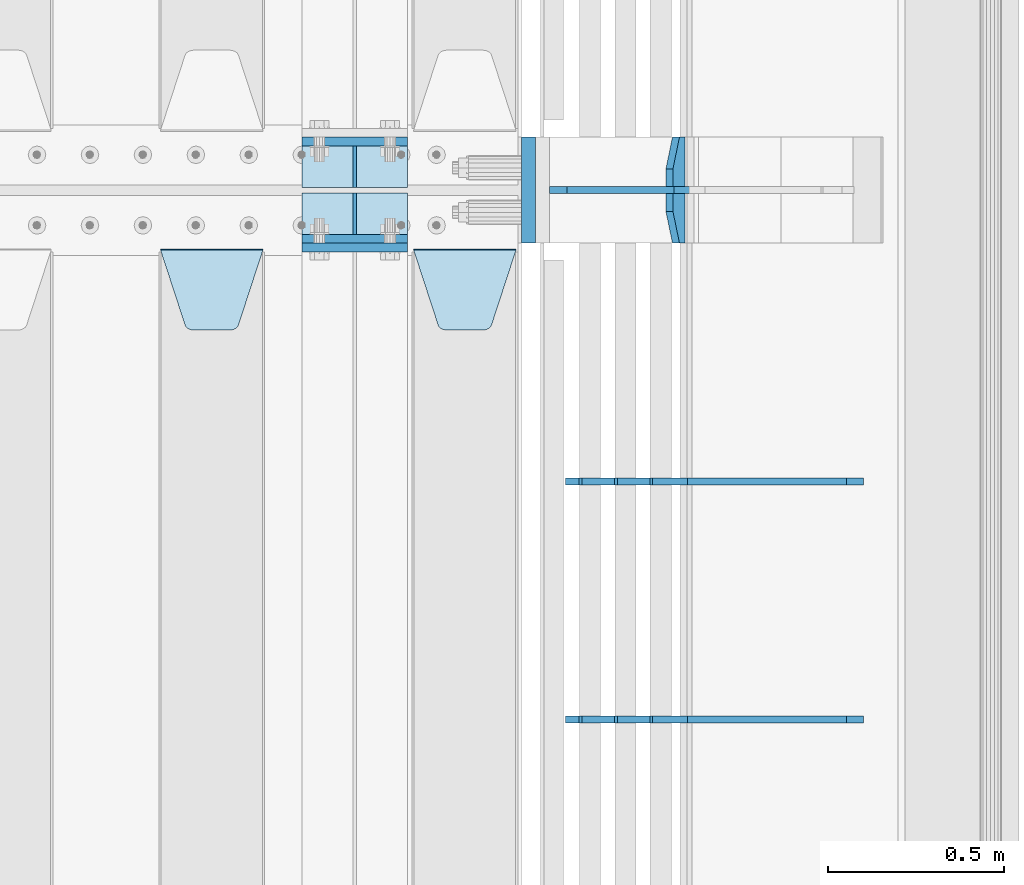
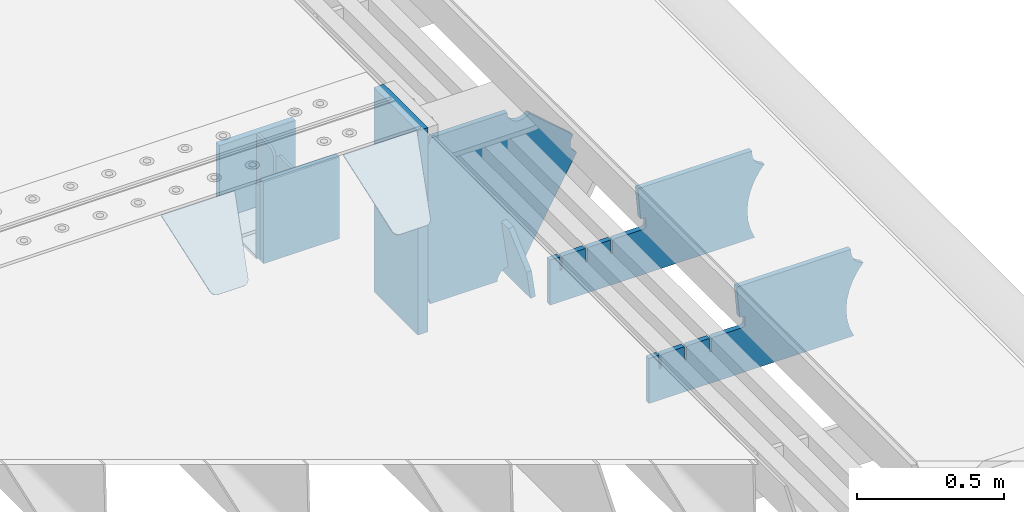
# One storey, part 170 of 193: 14 plates.
"""IFC2X3 building model written with IfcOpenShell, lengths in millimetres."""

from ifc_helpers import new_model, si_unit, frame, origin_with_axes, place, context, subcontext, project, spatial, faceted_brep, material, type_object, element, save


model = new_model("IFC2X3")

# Units and contexts
model_context = context("Model", 3, precision=1e-05, world=origin_with_axes())
body_context = subcontext(model_context, "Body", "Model", "MODEL_VIEW")
ifc_project = project(units=[si_unit("LENGTHUNIT", "METRE", prefix="MILLI"), si_unit("AREAUNIT", "SQUARE_METRE"), si_unit("VOLUMEUNIT", "CUBIC_METRE"), si_unit("MASSUNIT", "GRAM", prefix="KILO"), si_unit("TIMEUNIT", "SECOND"), si_unit("PLANEANGLEUNIT", "RADIAN"), si_unit("SOLIDANGLEUNIT", "STERADIAN"), si_unit("THERMODYNAMICTEMPERATUREUNIT", "DEGREE_CELSIUS"), si_unit("LUMINOUSINTENSITYUNIT", "LUMEN")], contexts=[model_context])

# Site, building, storey
site_placement = place(None, origin_with_axes())
site = spatial("IfcSite", under=ifc_project, at=site_placement, CompositionType="ELEMENT")
building_placement = place(site_placement, origin_with_axes())
building = spatial("IfcBuilding", under=site, at=building_placement, Name="Standard", CompositionType="ELEMENT")
storey_placement = place(building_placement, origin_with_axes())
storey = spatial("IfcBuildingStorey", under=building, at=storey_placement, Name="Undefined", CompositionType="ELEMENT", Elevation=0.0)

# Plates
ifc_material_1 = material(Name="STEEL/S355N")
plate_type_1 = type_object("IfcPlateType", PredefinedType="NOTDEFINED")
for number, where, z_axis, x_axis in (
    (1, (-29045.0, 27137.5, -339.999999999995), (0.0, 0.0, 1.0), (1.0, 0.0, 0.0)),
    (2, (-29045.0, 26862.5, -339.999999999995), (0.0, 0.0, 1.0), (1.0, 0.0, 0.0)),
):
    element("IfcPlate", number, at=place(storey_placement, frame(where, z_axis=z_axis, x_axis=x_axis)), inside=storey, type_object=plate_type_1, material=ifc_material_1, context=body_context, shape_type="Brep", body=[
        faceted_brep([(0.0, -12.5, 0.0), (0.0, -12.5, 310.0), (0.0, 12.5, 310.0), (0.0, 12.5, 0.0), (300.0, -12.5, 310.0), (300.0, 12.5, 310.0), (300.0, -12.5, 0.0), (300.0, 12.5, 0.0)], [[[0, 1, 2, 3]], [[1, 4, 5, 2]], [[4, 6, 7, 5]], [[6, 0, 3, 7]], [[5, 7, 3, 2]], [[6, 4, 1, 0]]]),
    ])
plate_1_placement = place(storey_placement, frame((-29045.0, 26837.5, -340.000000000044), z_axis=(0.0, 0.0, 1.0), x_axis=(1.0, 0.0, 0.0)))
element("IfcPlate", 3, at=plate_1_placement, inside=storey, type_object=plate_type_1, material=ifc_material_1, context=body_context, shape_type="Brep", body=[
    faceted_brep([(0.0, -12.5, 0.0), (9.27684595808387e-10, -12.5, 340.0), (9.27684595808387e-10, 12.5, 340.0), (0.0, 12.5, 0.0), (300.0, -12.5, 340.0), (300.0, 12.5, 340.0), (300.0, -12.5, 0.0), (300.0, 12.5, 0.0)], [[[0, 1, 2, 3]], [[1, 4, 5, 2]], [[4, 6, 7, 5]], [[6, 0, 3, 7]], [[5, 7, 3, 2]], [[6, 4, 1, 0]]]),
])
plate_type_2 = type_object("IfcPlateType", PredefinedType="NOTDEFINED")
for number, where, z_axis, x_axis in (
    (4, (-29045.0, 27008.0, -342.999999999995), (0.0, 1.0, 0.0), (1.0, 0.0, 0.0)),
    (5, (-29045.0, 26992.0, -342.999999999995), (0.0, -1.0, 0.0), (1.0, 0.0, 0.0)),
):
    element("IfcPlate", number, at=place(storey_placement, frame(where, z_axis=z_axis, x_axis=x_axis)), inside=storey, type_object=plate_type_2, material=ifc_material_1, context=body_context, shape_type="Brep", body=[
        faceted_brep([(0.0, -7.0, 0.0), (0.0, -7.0, 117.0), (0.0, 7.0, 117.0), (0.0, 7.0, 0.0), (300.0, -7.0, 117.0), (300.0, 7.0, 117.0), (300.0, -7.0, 0.0), (300.0, 7.0, 0.0)], [[[0, 1, 2, 3]], [[1, 4, 5, 2]], [[4, 6, 7, 5]], [[6, 0, 3, 7]], [[5, 7, 3, 2]], [[6, 4, 1, 0]]]),
    ])
plate_type_3 = type_object("IfcPlateType", PredefinedType="NOTDEFINED")
for number, where, z_axis, x_axis in (
    (6, (-28895.0, 27008.0, -29.9999999999945), (0.0, 0.0, -1.0), (0.0, 1.0, 0.0)),
    (7, (-28895.0, 26992.0, -29.9999999999945), (0.0, 0.0, -1.0), (0.0, -1.0, 0.0)),
):
    element("IfcPlate", number, at=place(storey_placement, frame(where, z_axis=z_axis, x_axis=x_axis)), inside=storey, type_object=plate_type_3, material=ifc_material_1, context=body_context, shape_type="Brep", body=[
        faceted_brep([(0.0, -5.0, 30.0), (0.0, -5.0, 306.0), (0.0, 5.0, 306.0), (0.0, 5.0, 30.0), (117.0, -5.0, 306.0), (117.0, 5.0, 306.0), (117.0, -5.0, 0.0), (117.0, 5.0, 0.0), (30.0, -5.0, 0.0), (30.0, 5.0, 0.0), (24.7905546699913, -5.0, 0.455767409633758), (24.7905546699913, 5.0, 0.455767409633758), (19.7393957002314, -5.0, 1.80922137642275), (19.7393957002314, 5.0, 1.80922137642275), (15.0, -5.0, 4.01923788646684), (15.0, 5.0, 4.01923788646684), (10.7163717094045, -5.0, 7.01866670643066), (10.7163717094045, 5.0, 7.01866670643066), (7.01866670642994, -5.0, 10.7163717094038), (7.01866670642994, 5.0, 10.7163717094038), (4.01923788646673, -5.0, 15.0), (4.01923788646673, 5.0, 15.0), (1.80922137642119, -5.0, 19.7393957002299), (1.80922137642119, 5.0, 19.7393957002299), (0.455767409632244, -5.0, 24.7905546699921), (0.455767409632244, 5.0, 24.7905546699921)], [[[0, 1, 2, 3]], [[1, 4, 5, 2]], [[4, 6, 7, 5]], [[6, 8, 9, 7]], [[8, 10, 11, 9]], [[10, 12, 13, 11]], [[12, 14, 15, 13]], [[14, 16, 17, 15]], [[16, 18, 19, 17]], [[18, 20, 21, 19]], [[20, 22, 23, 21]], [[22, 24, 25, 23]], [[24, 0, 3, 25]], [[5, 7, 9, 11, 13, 15, 17, 19, 21, 23, 25, 3, 2]], [[24, 22, 20, 18, 16, 14, 12, 10, 8, 6, 4, 1, 0]]]),
    ])
plate_type_4 = type_object("IfcPlateType", PredefinedType="NOTDEFINED")
plate_2_placement = place(storey_placement, frame((-28728.0, 26831.767766956, -1.76776695296758), z_axis=(0.0, -0.707106781186547, -0.707106781186548), x_axis=(1.0, 0.0, 0.0)))
element("IfcPlate", 8, at=plate_2_placement, inside=storey, type_object=plate_type_4, material=ifc_material_1, context=body_context, shape_type="Brep", body=[
    faceted_brep([(0.0, -2.5, 0.0), (69.345504679477, -2.50000000000364, 300.171731424831), (69.345504679477, 2.49999999999636, 300.171731424831), (0.0, 2.5, 0.0), (70.9274061199576, -2.50000000000364, 304.897442415397), (70.9274061199576, 2.49999999999636, 304.897442415397), (73.3818627772307, -2.50000000000364, 309.234538108529), (73.3818627772307, 2.49999999999636, 309.234538108529), (76.6187032999551, -2.50000000000728, 313.023683126103), (76.6187032999551, 2.49999999999636, 313.023683126103), (80.5190132704993, -2.50000000000364, 316.125672595372), (80.5190132704993, 2.49999999999636, 316.125672595368), (84.9395038596849, -2.50000000000364, 318.426546230472), (84.9395038596849, 2.49999999999636, 318.426546230476), (89.7177759439219, -2.50000000000364, 319.841774983273), (89.7177759439219, 2.49999999999636, 319.841774983277), (94.678286292652, -2.50000000000364, 320.319366455074), (94.678286292652, 2.49999999999636, 320.319366455074), (195.321713707348, -2.50000000000364, 320.319366455074), (195.321713707348, 2.49999999999636, 320.319366455074), (200.282224056078, -2.50000000000364, 319.841774983273), (200.282224056078, 2.49999999999636, 319.841774983277), (205.060496140315, -2.50000000000364, 318.426546230472), (205.060496140315, 2.49999999999636, 318.426546230472), (209.480986729501, -2.50000000000364, 316.125672595372), (209.480986729501, 2.49999999999636, 316.125672595368), (213.381296700045, -2.50000000000728, 313.023683126103), (213.381296700045, 2.49999999999272, 313.023683126103), (216.618137222769, -2.50000000000364, 309.234538108525), (216.618137222769, 2.49999999999636, 309.234538108522), (219.072593880042, -2.50000000000364, 304.897442415397), (219.072593880042, 2.49999999999636, 304.897442415397), (220.654495320523, -2.50000000000364, 300.171731424831), (220.654495320523, 2.49999999999636, 300.171731424831), (290.0, -2.50000000000364, 0.0), (290.0, 2.49999999999636, 0.0)], [[[0, 1, 2, 3]], [[1, 4, 5, 2]], [[4, 6, 7, 5]], [[6, 8, 9, 7]], [[8, 10, 11, 9]], [[10, 12, 13, 11]], [[12, 14, 15, 13]], [[14, 16, 17, 15]], [[16, 18, 19, 17]], [[18, 20, 21, 19]], [[20, 22, 23, 21]], [[22, 24, 25, 23]], [[24, 26, 27, 25]], [[26, 28, 29, 27]], [[28, 30, 31, 29]], [[30, 32, 33, 31]], [[32, 34, 35, 33]], [[34, 0, 3, 35]], [[5, 7, 9, 11, 13, 15, 17, 19, 21, 23, 25, 27, 29, 31, 33, 35, 3, 2]], [[34, 32, 30, 28, 26, 24, 22, 20, 18, 16, 14, 12, 10, 8, 6, 4, 1, 0]]]),
])
plate_3_placement = place(storey_placement, frame((-29445.0, 26831.767766956, -1.76776695296758), z_axis=(0.0, -0.707106781186547, -0.707106781186548), x_axis=(1.0, 0.0, 0.0)))
element("IfcPlate", 9, at=plate_3_placement, inside=storey, type_object=plate_type_4, material=ifc_material_1, context=body_context, shape_type="Brep", body=[
    faceted_brep([(0.0, -2.5, 0.0), (69.345504679477, -2.50000000000364, 300.171731424831), (69.345504679477, 2.49999999999636, 300.171731424831), (0.0, 2.5, 0.0), (70.9274061199576, -2.50000000000364, 304.897442415397), (70.9274061199576, 2.49999999999636, 304.897442415397), (73.3818627772307, -2.50000000000364, 309.234538108529), (73.3818627772307, 2.49999999999636, 309.234538108529), (76.6187032999551, -2.50000000000728, 313.023683126103), (76.6187032999551, 2.49999999999636, 313.023683126103), (80.5190132704993, -2.50000000000364, 316.125672595372), (80.5190132704993, 2.49999999999636, 316.125672595368), (84.9395038596849, -2.50000000000364, 318.426546230472), (84.9395038596849, 2.49999999999636, 318.426546230476), (89.7177759439219, -2.50000000000364, 319.841774983273), (89.7177759439219, 2.49999999999636, 319.841774983277), (94.678286292652, -2.50000000000364, 320.319366455074), (94.678286292652, 2.49999999999636, 320.319366455074), (195.321713707348, -2.50000000000364, 320.319366455074), (195.321713707348, 2.49999999999636, 320.319366455074), (200.282224056078, -2.50000000000364, 319.841774983273), (200.282224056078, 2.49999999999636, 319.841774983277), (205.060496140315, -2.50000000000364, 318.426546230472), (205.060496140315, 2.49999999999636, 318.426546230472), (209.480986729501, -2.50000000000364, 316.125672595372), (209.480986729501, 2.49999999999636, 316.125672595368), (213.381296700045, -2.50000000000728, 313.023683126103), (213.381296700045, 2.49999999999272, 313.023683126103), (216.618137222769, -2.50000000000364, 309.234538108525), (216.618137222769, 2.49999999999636, 309.234538108522), (219.072593880042, -2.50000000000364, 304.897442415397), (219.072593880042, 2.49999999999636, 304.897442415397), (220.654495320523, -2.50000000000364, 300.171731424831), (220.654495320523, 2.49999999999636, 300.171731424831), (290.0, -2.50000000000364, 0.0), (290.0, 2.49999999999636, 0.0)], [[[0, 1, 2, 3]], [[1, 4, 5, 2]], [[4, 6, 7, 5]], [[6, 8, 9, 7]], [[8, 10, 11, 9]], [[10, 12, 13, 11]], [[12, 14, 15, 13]], [[14, 16, 17, 15]], [[16, 18, 19, 17]], [[18, 20, 21, 19]], [[20, 22, 23, 21]], [[22, 24, 25, 23]], [[24, 26, 27, 25]], [[26, 28, 29, 27]], [[28, 30, 31, 29]], [[30, 32, 33, 31]], [[32, 34, 35, 33]], [[34, 0, 3, 35]], [[5, 7, 9, 11, 13, 15, 17, 19, 21, 23, 25, 27, 29, 31, 33, 35, 3, 2]], [[34, 32, 30, 28, 26, 24, 22, 20, 18, 16, 14, 12, 10, 8, 6, 4, 1, 0]]]),
])
plate_type_5 = type_object("IfcPlateType", PredefinedType="NOTDEFINED")
plate_4_placement = place(storey_placement, frame((-27968.9224668054, 27150.0000000017, -871.412303810021), z_axis=(0.0, -1.0, 0.0), x_axis=(-0.137902988002446, 0.0, 0.990445741017648)))
element("IfcPlate", 10, at=plate_4_placement, inside=storey, type_object=plate_type_5, material=ifc_material_1, context=body_context, shape_type="Brep", body=[
    faceted_brep([(0.0, -10.0, 0.0), (-1.97815097635612e-10, -9.99999999999272, 300.0), (-1.97360350284725e-10, 10.0000000000109, 300.0), (0.0, 10.0, 0.0), (115.000000000001, -9.99999999999272, 300.0), (115.0, 10.0000000000036, 300.0), (250.000000000001, -9.99999999998909, 210.0), (250.0, 10.0000000000073, 210.0), (250.000000000001, -9.99999999998909, 90.0), (250.0, 10.0000000000073, 90.0), (115.000000000001, -9.99999999999272, -1.09139364212751e-10), (115.0, 10.0000000000036, -1.09139364212751e-10)], [[[0, 1, 2, 3]], [[1, 4, 5, 2]], [[4, 6, 7, 5]], [[6, 8, 9, 7]], [[8, 10, 11, 9]], [[10, 0, 3, 11]], [[5, 7, 9, 11, 3, 2]], [[10, 8, 6, 4, 1, 0]]]),
])
ifc_material_2 = material()
plate_type_6 = type_object("IfcPlateType", PredefinedType="NOTDEFINED")
plate_5_placement = place(storey_placement, frame((-28403.0, 27150.0, -870.0), z_axis=(0.0, 0.0, 1.0), x_axis=(0.0, -1.0, 0.0)))
element("IfcPlate", 11, at=plate_5_placement, inside=storey, type_object=plate_type_6, material=ifc_material_2, context=body_context, shape_type="Brep", body=[
    faceted_brep([(0.0, -20.0, 0.0), (0.0, -20.0, 850.0), (0.0, 20.0, 850.0), (0.0, 20.0, 0.0), (300.0, -20.0, 850.0), (300.0, 20.0, 850.0), (300.0, -20.0, 0.0), (300.0, 20.0, 0.0)], [[[0, 1, 2, 3]], [[1, 4, 5, 2]], [[4, 6, 7, 5]], [[6, 0, 3, 7]], [[5, 7, 3, 2]], [[6, 4, 1, 0]]]),
])
plate_type_7 = type_object("IfcPlateType", PredefinedType="NOTDEFINED")
plate_6_placement = place(storey_placement, frame((-27457.0817660324, 25499.9992828369, -374.002067436517), z_axis=(0.0, 0.0, 1.0), x_axis=(-1.0, 0.0, 0.0)))
element("IfcPlate", 12, at=plate_6_placement, inside=storey, type_object=plate_type_7, material=ifc_material_1, context=body_context, shape_type="Brep", body=[
    faceted_brep([(801.919404066546, -10.0, 188.0), (801.919404066546, 10.0, 188.0), (801.919404066546, 10.0, 132.002067436952), (801.919404066546, -10.0, 132.002067436952), (793.919404066546, 10.0, 132.002067436952), (793.919404066546, -10.0, 132.002067436952), (793.919404066546, 10.0, 180.002067436952), (793.919404066546, -10.0, 180.002067436952), (793.527856196906, 10.0, 182.474203391951), (793.527856196906, -10.0, 182.474203391951), (792.391540021545, 10.0, 184.704349455291), (792.391540021545, -10.0, 184.704349455291), (790.621686084887, 10.0, 186.474203391951), (790.621686084887, -10.0, 186.474203391951), (788.391540021545, 10.0, 187.610519567313), (788.391540021545, -10.0, 187.610519567313), (785.919404066546, -10.0, 188.002067436952), (785.919404066546, 10.0, 188.0), (841.0, -10.0, 188.0), (841.0, -10.0, 0.0), (841.0, 10.0, 0.0), (841.0, 10.0, 188.0), (33.3619566736015, -10.0, 0.0), (33.3619566736015, 10.0, 0.0), (36.2350612208174, -10.0, 4.68848050267007), (36.2350612208174, 10.0, 4.68848050267007), (51.4877592159428, -10.0, 41.5117508652783), (51.4877592159428, 10.0, 41.5117508652783), (60.792242588137, -10.0, 80.2677133162963), (60.792242588137, 10.0, 80.2677133162963), (63.9194040769726, -10.0, 120.002067436515), (63.9194040769726, 10.0, 120.002067436515), (60.792242588137, -10.0, 159.736421556734), (60.792242588137, 10.0, 159.736421556734), (51.4877592159428, -10.0, 198.492384007752), (51.4877592159428, 10.0, 198.492384007752), (36.2350612208174, -10.0, 235.31565437036), (36.2350612208174, 10.0, 235.31565437036), (15.4097206482074, -10.0, 269.299521518803), (15.4097206482074, 10.0, 269.299521518803), (-3.35474438098754, -10.0, 291.269887256574), (-3.35474438098754, 10.0, 291.269887256574), (-2.36881039375294, -10.0, 291.426043859339), (-2.36881039375294, 10.0, 291.426043859339), (17.1449676604716, -10.0, 301.368810393754), (17.1449676604716, 10.0, 301.368810393754), (32.6311896062471, -10.0, 316.855032339527), (32.6311896062471, 10.0, 316.855032339527), (42.573956140659, -10.0, 336.368810393754), (42.573956140659, 10.0, 336.368810393754), (46.0, -10.0, 358.0), (46.0, 10.0, 358.0), (45.0495205499137, -10.0, 364.001091067617), (45.0495205499137, 10.0, 364.001091067617), (495.040008544922, -10.0, 364.010009765625), (495.040008544922, 10.0, 364.010009765625), (483.600036621094, -10.0, 233.759994506836), (483.600036621094, 10.0, 233.759994506836), (472.0, -10.0, 233.759994506836), (472.0, 10.0, 233.759994506836), (468.909830056251, -10.0, 233.270559669787), (468.909830056251, 10.0, 233.270559669787), (466.122147477075, -10.0, 231.850164450585), (466.122147477075, 10.0, 231.850164450585), (463.909830056251, -10.0, 229.637847029761), (463.909830056251, 10.0, 229.637847029761), (462.489434837047, -10.0, 226.850164450585), (462.489434837047, 10.0, 226.850164450585), (462.0, -10.0, 223.759994506836), (462.0, 10.0, 223.759994506836), (462.0, -10.0, 198.0), (462.0, 10.0, 198.0), (462.489434837047, -10.0, 194.909830056251), (462.489434837047, 10.0, 194.909830056251), (463.909830056251, -10.0, 192.122147477075), (463.909830056251, 10.0, 192.122147477075), (466.122147477075, -10.0, 189.909830056251), (466.122147477075, 10.0, 189.909830056251), (468.909830056251, -10.0, 188.489434837048), (468.909830056251, 10.0, 188.489434837048), (472.0, -10.0, 188.0), (472.0, 10.0, 188.0), (585.919404066546, -10.0, 188.002067436952), (585.919404066546, 10.0, 188.0), (588.391540021545, -10.0, 187.610519567313), (588.391540021545, 10.0, 187.610519567313), (590.621686084887, -10.0, 186.474203391951), (590.621686084887, 10.0, 186.474203391951), (592.391540021545, -10.0, 184.704349455291), (592.391540021545, 10.0, 184.704349455291), (593.527856196906, -10.0, 182.474203391951), (593.527856196906, 10.0, 182.474203391951), (593.919404066546, -10.0, 180.002067436952), (593.919404066546, 10.0, 180.002067436952), (593.919404066546, -10.0, 132.002067436952), (593.919404066546, 10.0, 132.002067436952), (601.919404066546, -10.0, 132.002067436952), (601.919404066546, 10.0, 132.002067436952), (601.919404066546, -10.0, 188.0), (601.919404066546, 10.0, 188.0), (685.919404066546, -10.0, 188.002067436952), (685.919404066546, 10.0, 188.0), (688.391540021545, -10.0, 187.610519567313), (688.391540021545, 10.0, 187.610519567313), (690.621686084887, -10.0, 186.474203391951), (690.621686084887, 10.0, 186.474203391951), (692.391540021545, -10.0, 184.704349455291), (692.391540021545, 10.0, 184.704349455291), (693.527856196906, -10.0, 182.474203391951), (693.527856196906, 10.0, 182.474203391951), (693.919404066546, -10.0, 180.002067436952), (693.919404066546, 10.0, 180.002067436952), (693.919404066546, -10.0, 132.002067436952), (693.919404066546, 10.0, 132.002067436952), (701.919404066546, -10.0, 132.002067436952), (701.919404066546, 10.0, 132.002067436952), (701.919404066546, -10.0, 188.0), (701.919404066546, 10.0, 188.0)], [[[0, 1, 2, 3]], [[3, 2, 4, 5]], [[5, 4, 6, 7]], [[7, 6, 8, 9]], [[9, 8, 10, 11]], [[11, 10, 12, 13]], [[13, 12, 14, 15]], [[16, 15, 14, 17]], [[18, 19, 20, 21]], [[20, 19, 22, 23]], [[22, 24, 25, 23]], [[26, 27, 25, 24]], [[28, 29, 27, 26]], [[30, 31, 29, 28]], [[32, 33, 31, 30]], [[34, 35, 33, 32]], [[36, 37, 35, 34]], [[38, 39, 37, 36]], [[39, 38, 40, 41]], [[40, 42, 43, 41]], [[44, 45, 43, 42]], [[46, 47, 45, 44]], [[48, 49, 47, 46]], [[50, 51, 49, 48]], [[52, 53, 51, 50]], [[54, 55, 53, 52]], [[54, 56, 57, 55]], [[56, 58, 59, 57]], [[58, 60, 61, 59]], [[60, 62, 63, 61]], [[62, 64, 65, 63]], [[64, 66, 67, 65]], [[66, 68, 69, 67]], [[68, 70, 71, 69]], [[70, 72, 73, 71]], [[72, 74, 75, 73]], [[74, 76, 77, 75]], [[76, 78, 79, 77]], [[78, 80, 81, 79]], [[81, 80, 82, 83]], [[82, 84, 85, 83]], [[86, 87, 85, 84]], [[88, 89, 87, 86]], [[90, 91, 89, 88]], [[92, 93, 91, 90]], [[94, 95, 93, 92]], [[96, 97, 95, 94]], [[98, 99, 97, 96]], [[99, 98, 100, 101]], [[100, 102, 103, 101]], [[104, 105, 103, 102]], [[106, 107, 105, 104]], [[108, 109, 107, 106]], [[110, 111, 109, 108]], [[112, 113, 111, 110]], [[114, 115, 113, 112]], [[116, 117, 115, 114]], [[117, 116, 16, 17]], [[12, 10, 8, 6, 4, 2, 1, 21, 20, 23, 25, 27, 29, 31, 33, 35, 37, 39, 41, 43, 45, 47, 49, 51, 53, 55, 57, 59, 61, 63, 65, 67, 69, 71, 73, 75, 77, 79, 81, 83, 85, 87, 89, 91, 93, 95, 97, 99, 101, 103, 105, 107, 109, 111, 113, 115, 117, 17, 14]], [[18, 21, 1, 0]], [[116, 114, 112, 110, 108, 106, 104, 102, 100, 98, 96, 94, 92, 90, 88, 86, 84, 82, 80, 78, 76, 74, 72, 70, 68, 66, 64, 62, 60, 58, 56, 54, 52, 50, 48, 46, 44, 42, 40, 38, 36, 34, 32, 30, 28, 26, 24, 22, 19, 18, 0, 3, 5, 7, 9, 11, 13, 15, 16]]]),
])
plate_7_placement = place(storey_placement, frame((-27457.0817660324, 26174.9992828369, -374.002067436516), z_axis=(0.0, 0.0, 1.0), x_axis=(-1.0, 0.0, 0.0)))
element("IfcPlate", 13, at=plate_7_placement, inside=storey, type_object=plate_type_7, material=ifc_material_1, context=body_context, shape_type="Brep", body=[
    faceted_brep([(801.919404066546, -10.0, 188.0), (801.919404066546, 10.0, 188.0), (801.919404066546, 10.0, 132.002067436952), (801.919404066546, -10.0, 132.002067436952), (793.919404066546, 10.0, 132.002067436952), (793.919404066546, -10.0, 132.002067436952), (793.919404066546, 10.0, 180.002067436952), (793.919404066546, -10.0, 180.002067436952), (793.527856196906, 10.0, 182.474203391951), (793.527856196906, -10.0, 182.474203391951), (792.391540021545, 10.0, 184.704349455291), (792.391540021545, -10.0, 184.704349455291), (790.621686084887, 10.0, 186.474203391951), (790.621686084887, -10.0, 186.474203391951), (788.391540021545, 10.0, 187.610519567313), (788.391540021545, -10.0, 187.610519567313), (785.919404066546, -10.0, 188.002067436952), (785.919404066546, 10.0, 188.0), (841.0, -10.0, 188.0), (841.0, -10.0, 0.0), (841.0, 10.0, 0.0), (841.0, 10.0, 188.0), (33.3619566736015, -10.0, 0.0), (33.3619566736015, 10.0, 0.0), (36.2350612208174, -10.0, 4.68848050267007), (36.2350612208174, 10.0, 4.68848050267007), (51.4877592159428, -10.0, 41.5117508652783), (51.4877592159428, 10.0, 41.5117508652783), (60.792242588137, -10.0, 80.2677133162963), (60.792242588137, 10.0, 80.2677133162963), (63.9194040769726, -10.0, 120.002067436515), (63.9194040769726, 10.0, 120.002067436515), (60.792242588137, -10.0, 159.736421556734), (60.792242588137, 10.0, 159.736421556734), (51.4877592159428, -10.0, 198.492384007752), (51.4877592159428, 10.0, 198.492384007752), (36.2350612208174, -10.0, 235.31565437036), (36.2350612208174, 10.0, 235.31565437036), (15.4097206482074, -10.0, 269.299521518803), (15.4097206482074, 10.0, 269.299521518803), (-3.35474438098754, -10.0, 291.269887256574), (-3.35474438098754, 10.0, 291.269887256574), (-2.36881039375294, -10.0, 291.426043859339), (-2.36881039375294, 10.0, 291.426043859339), (17.1449676604716, -10.0, 301.368810393754), (17.1449676604716, 10.0, 301.368810393754), (32.6311896062471, -10.0, 316.855032339527), (32.6311896062471, 10.0, 316.855032339527), (42.573956140659, -10.0, 336.368810393754), (42.573956140659, 10.0, 336.368810393754), (46.0, -10.0, 358.0), (46.0, 10.0, 358.0), (45.0495205499137, -10.0, 364.001091067617), (45.0495205499137, 10.0, 364.001091067617), (495.040008544922, -10.0, 364.010009765625), (495.040008544922, 10.0, 364.010009765625), (483.600036621094, -10.0, 233.759994506836), (483.600036621094, 10.0, 233.759994506836), (472.0, -10.0, 233.759994506836), (472.0, 10.0, 233.759994506836), (468.909830056251, -10.0, 233.270559669787), (468.909830056251, 10.0, 233.270559669787), (466.122147477075, -10.0, 231.850164450585), (466.122147477075, 10.0, 231.850164450585), (463.909830056251, -10.0, 229.637847029761), (463.909830056251, 10.0, 229.637847029761), (462.489434837047, -10.0, 226.850164450585), (462.489434837047, 10.0, 226.850164450585), (462.0, -10.0, 223.759994506836), (462.0, 10.0, 223.759994506836), (462.0, -10.0, 198.0), (462.0, 10.0, 198.0), (462.489434837047, -10.0, 194.909830056251), (462.489434837047, 10.0, 194.909830056251), (463.909830056251, -10.0, 192.122147477075), (463.909830056251, 10.0, 192.122147477075), (466.122147477075, -10.0, 189.909830056251), (466.122147477075, 10.0, 189.909830056251), (468.909830056251, -10.0, 188.489434837048), (468.909830056251, 10.0, 188.489434837048), (472.0, -10.0, 188.0), (472.0, 10.0, 188.0), (585.919404066546, -10.0, 188.002067436952), (585.919404066546, 10.0, 188.0), (588.391540021545, -10.0, 187.610519567313), (588.391540021545, 10.0, 187.610519567313), (590.621686084887, -10.0, 186.474203391951), (590.621686084887, 10.0, 186.474203391951), (592.391540021545, -10.0, 184.704349455291), (592.391540021545, 10.0, 184.704349455291), (593.527856196906, -10.0, 182.474203391951), (593.527856196906, 10.0, 182.474203391951), (593.919404066546, -10.0, 180.002067436952), (593.919404066546, 10.0, 180.002067436952), (593.919404066546, -10.0, 132.002067436952), (593.919404066546, 10.0, 132.002067436952), (601.919404066546, -10.0, 132.002067436952), (601.919404066546, 10.0, 132.002067436952), (601.919404066546, -10.0, 188.0), (601.919404066546, 10.0, 188.0), (685.919404066546, -10.0, 188.002067436952), (685.919404066546, 10.0, 188.0), (688.391540021545, -10.0, 187.610519567313), (688.391540021545, 10.0, 187.610519567313), (690.621686084887, -10.0, 186.474203391951), (690.621686084887, 10.0, 186.474203391951), (692.391540021545, -10.0, 184.704349455291), (692.391540021545, 10.0, 184.704349455291), (693.527856196906, -10.0, 182.474203391951), (693.527856196906, 10.0, 182.474203391951), (693.919404066546, -10.0, 180.002067436952), (693.919404066546, 10.0, 180.002067436952), (693.919404066546, -10.0, 132.002067436952), (693.919404066546, 10.0, 132.002067436952), (701.919404066546, -10.0, 132.002067436952), (701.919404066546, 10.0, 132.002067436952), (701.919404066546, -10.0, 188.0), (701.919404066546, 10.0, 188.0)], [[[0, 1, 2, 3]], [[3, 2, 4, 5]], [[5, 4, 6, 7]], [[7, 6, 8, 9]], [[9, 8, 10, 11]], [[11, 10, 12, 13]], [[13, 12, 14, 15]], [[16, 15, 14, 17]], [[18, 19, 20, 21]], [[20, 19, 22, 23]], [[22, 24, 25, 23]], [[26, 27, 25, 24]], [[28, 29, 27, 26]], [[30, 31, 29, 28]], [[32, 33, 31, 30]], [[34, 35, 33, 32]], [[36, 37, 35, 34]], [[38, 39, 37, 36]], [[39, 38, 40, 41]], [[40, 42, 43, 41]], [[44, 45, 43, 42]], [[46, 47, 45, 44]], [[48, 49, 47, 46]], [[50, 51, 49, 48]], [[52, 53, 51, 50]], [[54, 55, 53, 52]], [[54, 56, 57, 55]], [[56, 58, 59, 57]], [[58, 60, 61, 59]], [[60, 62, 63, 61]], [[62, 64, 65, 63]], [[64, 66, 67, 65]], [[66, 68, 69, 67]], [[68, 70, 71, 69]], [[70, 72, 73, 71]], [[72, 74, 75, 73]], [[74, 76, 77, 75]], [[76, 78, 79, 77]], [[78, 80, 81, 79]], [[81, 80, 82, 83]], [[82, 84, 85, 83]], [[86, 87, 85, 84]], [[88, 89, 87, 86]], [[90, 91, 89, 88]], [[92, 93, 91, 90]], [[94, 95, 93, 92]], [[96, 97, 95, 94]], [[98, 99, 97, 96]], [[99, 98, 100, 101]], [[100, 102, 103, 101]], [[104, 105, 103, 102]], [[106, 107, 105, 104]], [[108, 109, 107, 106]], [[110, 111, 109, 108]], [[112, 113, 111, 110]], [[114, 115, 113, 112]], [[116, 117, 115, 114]], [[117, 116, 16, 17]], [[12, 10, 8, 6, 4, 2, 1, 21, 20, 23, 25, 27, 29, 31, 33, 35, 37, 39, 41, 43, 45, 47, 49, 51, 53, 55, 57, 59, 61, 63, 65, 67, 69, 71, 73, 75, 77, 79, 81, 83, 85, 87, 89, 91, 93, 95, 97, 99, 101, 103, 105, 107, 109, 111, 113, 115, 117, 17, 14]], [[18, 21, 1, 0]], [[116, 114, 112, 110, 108, 106, 104, 102, 100, 98, 96, 94, 92, 90, 88, 86, 84, 82, 80, 78, 76, 74, 72, 70, 68, 66, 64, 62, 60, 58, 56, 54, 52, 50, 48, 46, 44, 42, 40, 38, 36, 34, 32, 30, 28, 26, 24, 22, 19, 18, 0, 3, 5, 7, 9, 11, 13, 15, 16]]]),
])
plate_type_8 = type_object("IfcPlateType", PredefinedType="NOTDEFINED")
plate_8_placement = place(storey_placement, frame((-27940.0011701087, 27000.0000000001, -179.999999999866), z_axis=(0.0, 0.0, -1.0), x_axis=(-1.0, 0.0, 0.0)))
element("IfcPlate", 14, at=plate_8_placement, inside=storey, type_object=plate_type_8, material=ifc_material_1, context=body_context, shape_type="Brep", body=[
    faceted_brep([(46.0258547361482, 10.0, 641.078828352486), (73.3015011074858, 10.0000000000109, 445.179898435786), (73.3015011074858, -9.99999999998545, 445.179898435786), (46.0258547361482, -10.0, 641.078828352486), (53.4925862871314, 10.0000000000109, 442.421838675737), (53.4925862871314, -9.99999999998545, 442.421838675737), (25.782050112397, 10.0, 641.444230671289), (25.782050112397, -10.0, 641.444230671289), (54.6652503111618, 10.0, 642.447174185377), (54.6652503111618, -10.0, 642.447174185377), (68.6036632070354, -10.0, 649.549150281387), (68.6036632070354, 10.0, 649.549150281387), (79.6652503111618, -10.0, 660.610737385511), (79.6652503111618, 10.0, 660.610737385511), (86.7672264071698, -10.0, 674.549150281387), (86.7672264071698, 10.0, 674.549150281387), (89.2144005924129, -10.0, 690.0), (89.2144005924129, 10.0, 690.0), (353.0, -10.0, 690.0), (353.0, 10.0, 690.0), (355.447174185243, -10.0, 674.549150281253), (355.447174185243, 10.0, 674.549150281253), (362.549150281251, -10.0, 660.610737385376), (362.549150281251, 10.0, 660.610737385376), (373.610737385377, -10.0, 649.549150281253), (373.610737385377, 10.0, 649.549150281253), (387.549150281251, -10.0, 642.447174185242), (387.549150281251, 10.0, 642.447174185242), (403.0, -10.0, 640.0), (403.0, 10.0, 640.0), (403.0, -10.0, 50.0), (403.0, 10.0, 50.0), (387.549150281251, -10.0, 47.5528258147577), (387.549150281251, 10.0, 47.5528258147577), (373.610737385377, -10.0, 40.4508497187474), (373.610737385377, 10.0, 40.4508497187474), (362.549150281251, -10.0, 29.3892626146236), (362.549150281251, 10.0, 29.3892626146236), (355.447174185243, -10.0, 15.4508497187474), (355.447174185243, 10.0, 15.4508497187474), (353.0, -10.0, 0.0), (353.0, 10.0, 0.0), (50.0, -10.0, 0.0), (50.0, 10.0, 0.0), (47.0349915316328, -10.0, 16.9620037619133), (47.0349915316328, 10.0, 16.9620037619133), (38.4916171352343, -10.0, 31.9123081320451), (38.4916171352343, 10.0, 31.9123081320451), (25.3831239081519, -10.0, 43.0778019479116), (25.3831239081519, 10.0, 43.0778019479116), (9.26418358741648, -10.0, 49.1342538608113), (9.26418358741648, 10.0, 49.1342538608113), (-7.95349204488593, -10.0, 49.363366622344), (-7.95349204488593, 10.0, 49.363366622344), (-24.2278808265401, -10.0, 43.7379673813837), (-24.2278808265401, 10.0, 43.7379673813837), (-37.6288347353438, -10.0, 32.9252303934259), (-37.6288347353438, 10.0, 32.9252303934259), (-210.371165264656, -10.0, 184.074769606574), (-210.371165264656, 10.0, 184.074769606574), (-202.382363280569, -10.0, 196.529747922069), (-202.382363280569, 10.0, 196.529747922069), (-198.388707244045, -10.0, 210.777489969227), (-198.388707244045, 10.0, 210.777489969227), (-198.739957464426, -10.0, 225.570193077959), (-198.739957464426, 10.0, 225.570193077959), (-203.40535180681, -10.0, 239.612327446012), (-203.40535180681, 10.0, 239.612327446012), (-211.976299808361, -10.0, 251.674097313455), (-211.976299808361, 10.0, 251.674097313455), (-223.702166612962, -10.0, 260.699145216992), (-223.702166612962, 10.0, 260.699145216992), (-9.29783338703783, -10.0, 646.300854783008), (-9.29783338703783, 10.0, 646.300854783008), (6.98069453597782, -10.0, 640.647282345602), (6.98069453597782, 10.0, 640.647282345602), (24.2117663163663, -10.0, 640.855891896051), (24.2117663163663, 10.0, 640.855891896051)], [[[0, 1, 2, 3]], [[4, 5, 2, 1]], [[6, 7, 5, 4]], [[8, 9, 10, 11]], [[11, 10, 12, 13]], [[13, 12, 14, 15]], [[15, 14, 16, 17]], [[18, 19, 17, 16]], [[18, 20, 21, 19]], [[20, 22, 23, 21]], [[22, 24, 25, 23]], [[24, 26, 27, 25]], [[26, 28, 29, 27]], [[28, 30, 31, 29]], [[30, 32, 33, 31]], [[32, 34, 35, 33]], [[34, 36, 37, 35]], [[36, 38, 39, 37]], [[38, 40, 41, 39]], [[40, 42, 43, 41]], [[42, 44, 45, 43]], [[44, 46, 47, 45]], [[46, 48, 49, 47]], [[48, 50, 51, 49]], [[50, 52, 53, 51]], [[52, 54, 55, 53]], [[54, 56, 57, 55]], [[56, 58, 59, 57]], [[58, 60, 61, 59]], [[60, 62, 63, 61]], [[62, 64, 65, 63]], [[64, 66, 67, 65]], [[66, 68, 69, 67]], [[68, 70, 71, 69]], [[70, 72, 73, 71]], [[72, 74, 75, 73]], [[74, 76, 77, 75]], [[1, 0, 8, 11, 13, 15, 17, 19, 21, 23, 25, 27, 29, 31, 33, 35, 37, 39, 41, 43, 45, 47, 49, 51, 53, 55, 57, 59, 61, 63, 65, 67, 69, 71, 73, 75, 77, 6, 4]], [[9, 8, 0, 3]], [[76, 74, 72, 70, 68, 66, 64, 62, 60, 58, 56, 54, 52, 50, 48, 46, 44, 42, 40, 38, 36, 34, 32, 30, 28, 26, 24, 22, 20, 18, 16, 14, 12, 10, 9, 3, 2, 5, 7]], [[77, 76, 7, 6]]]),
])

save(model, "model.ifc")
